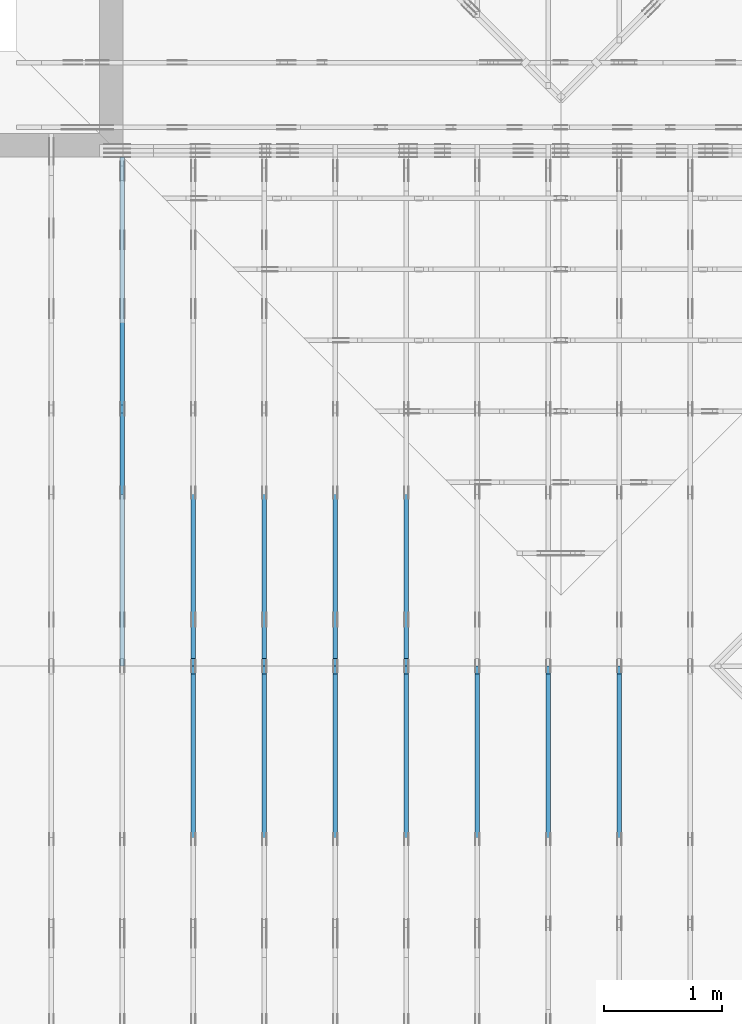
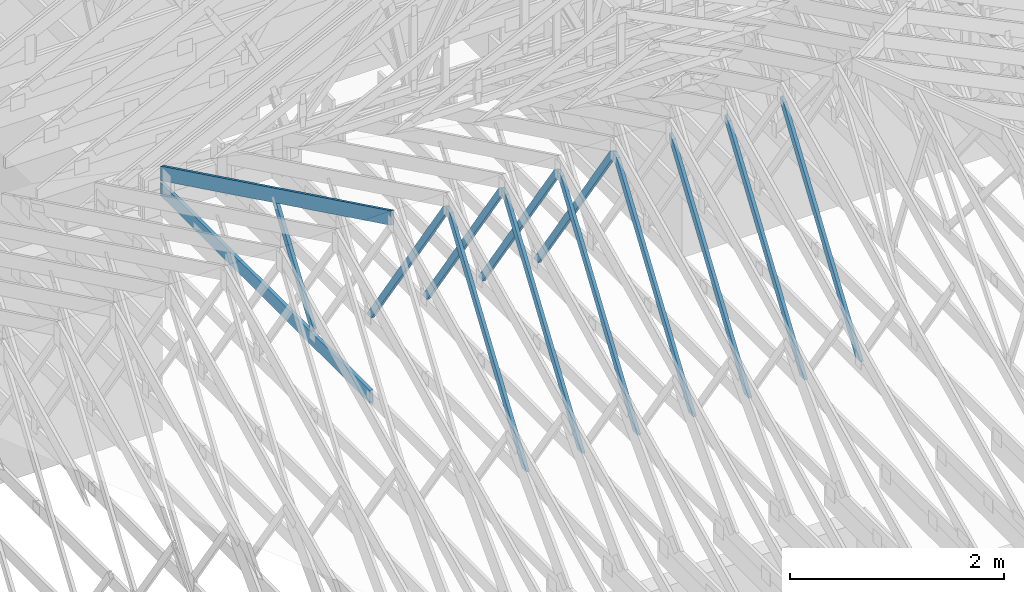
# One storey, part 17 of 159: 14 members, 8 elements without a shape of their own.
"""IFC2X3 building model written with IfcOpenShell, lengths in millimetres."""

from ifc_helpers import new_model, si_unit, frame, origin, origin_with_axes, origin_2d, place, context, project, spatial, faceted_brep, element, aggregate, save


model = new_model("IFC2X3")

# Units and contexts
model_context = context("Model", 3, precision=1e-05, world=origin())
plan_context = context("Plan", 2, precision=1e-05, world=origin_2d())
ifc_project = project(units=[si_unit("LENGTHUNIT", "METRE", prefix="MILLI"), si_unit("AREAUNIT", "SQUARE_METRE"), si_unit("VOLUMEUNIT", "CUBIC_METRE"), si_unit("SOLIDANGLEUNIT", "STERADIAN"), si_unit("PLANEANGLEUNIT", "RADIAN"), si_unit("MASSUNIT", "GRAM"), si_unit("TIMEUNIT", "SECOND"), si_unit("THERMODYNAMICTEMPERATUREUNIT", "DEGREE_CELSIUS"), si_unit("LUMINOUSINTENSITYUNIT", "LUMEN")], contexts=[model_context, plan_context])

# Site, building, storey
site_placement = place(None, origin_with_axes())
site = spatial("IfcSite", under=ifc_project, at=site_placement, CompositionType="ELEMENT")
building_placement = place(site_placement, origin_with_axes())
building = spatial("IfcBuilding", under=site, at=building_placement, Name="Plan 1", CompositionType="ELEMENT")
storey_placement = place(building_placement, origin_with_axes())
storey = spatial("IfcBuildingStorey", under=building, at=storey_placement, Name="Etasje 1", CompositionType="ELEMENT", Elevation=0.0)

# Assembly, member
assembly_1_placement = place(storey_placement, frame((15075.02226140475, -699.9989301294845, 1.1021457184401395e-15), z_axis=(-1.0, 1.836909530733566e-16, 6.123031769111886e-17), x_axis=(-1.836909530733566e-16, -1.0, 0.0)))
assembly_1 = element("IfcElementAssembly", 1, at=assembly_1_placement, inside=storey, Name="T7 (103)", AssemblyPlace="FACTORY", PredefinedType="TRUSS")
member_1_placement = place(assembly_1_placement, frame((-5230.134200945327, 2470.9490997577877, -36.0), z_axis=(0.0, 0.0, 1.0), x_axis=(0.5642475050069341, -0.8256056886271133, 0.0)))
member_1 = element("IfcMember", 2, at=member_1_placement, Name="T7-D10", context=model_context, shape_type="Brep", body=[
    faceted_brep([(2593.4163311647476, 73.00019205185345, 36.0), (64.12142578857947, 73.00019205185345, 36.0), (0.0, 36.500098826461, 36.0), (53.40677111084369, 6.283484799496364e-05, 36.0), (2543.5254730981324, 6.283484799496364e-05, 36.0), (64.12142578857947, 73.00019205185345, 7.852350543684446e-15), (2593.4163311647476, 73.00019205185345, 3.1759141172510683e-13), (2543.5254730981324, 6.283484799496364e-05, 3.114817455465041e-13), (53.40677111084369, 6.283484799496364e-05, 6.540227123947657e-15), (0.0, 36.500098826461, 0.0), (8.990210517012542e-05, 36.5000938930789, 3.944304526105059e-31), (8.990210517190178e-05, 36.50009389307889, 36.0), (64.12149423251047, 73.00009389364551, 36.0), (64.12149423251047, 73.00009389364551, 7.888609052210118e-31), (53.40680834923477, 9.3893645480847e-05, 1.1832913578315177e-30), (53.40680834923477, 9.389364548439971e-05, 36.0), (8.990210517723085e-05, 36.50009389307888, 36.0), (8.990210517723085e-05, 36.500093893078876, 3.944304526105059e-31), (2543.5255372683005, 9.389364500212836e-05, 1.1393273801051142e-28), (2543.5255372683005, 9.389364500433265e-05, 36.0), (53.40680834923478, 9.389364546174493e-05, 36.0), (53.40680834923478, 9.389364545954064e-05, 2.3922645400816085e-30), (2593.4162640800278, 73.00009389364232, -5.048709793414476e-29), (2593.4162640800278, 73.00009389364232, 36.0), (2543.5255372683, 9.38936470902263e-05, 36.0), (2543.5255372683, 9.38936470902263e-05, -5.048709793414476e-29), (64.12149423251049, 73.00009389364551, 0.0), (64.12149423251049, 73.00009389364551, 36.0), (2593.416264080028, 73.00009389364254, 36.0), (2593.416264080028, 73.00009389364254, 4.1809627976713626e-29)], [[[0, 1, 2, 3, 4]], [[5, 6, 7, 8, 9]], [[10, 11, 12, 13]], [[14, 15, 16, 17]], [[18, 19, 20, 21]], [[22, 23, 24, 25]], [[26, 27, 28, 29]]]),
])
aggregate(assembly_1, [member_1])

assembly_2_placement = place(storey_placement, frame((14475.022261404752, -699.9989301294836, 1.1021457184401395e-15), z_axis=(-1.0, 1.836909530733566e-16, 6.123031769111886e-17), x_axis=(-1.836909530733566e-16, -1.0, 0.0)))
assembly_2 = element("IfcElementAssembly", 3, at=assembly_2_placement, inside=storey, Name="T10 (102)", AssemblyPlace="FACTORY", PredefinedType="TRUSS")
member_2_placement = place(assembly_2_placement, frame((-5230.134200945327, 2470.9490997577877, -36.0), z_axis=(0.0, 0.0, 1.0), x_axis=(0.5642475050069341, -0.8256056886271133, 0.0)))
member_2 = element("IfcMember", 4, at=member_2_placement, Name="T10-D10", context=model_context, shape_type="Brep", body=[
    faceted_brep([(2593.4163311647476, 73.00019205185345, 36.0), (64.12142578857947, 73.00019205185345, 36.0), (0.0, 36.500098826461, 36.0), (53.40677111084369, 6.283484799496364e-05, 36.0), (2543.5254730981324, 6.283484799496364e-05, 36.0), (64.12142578857947, 73.00019205185345, 7.852350543684446e-15), (2593.4163311647476, 73.00019205185345, 3.1759141172510683e-13), (2543.5254730981324, 6.283484799496364e-05, 3.114817455465041e-13), (53.40677111084369, 6.283484799496364e-05, 6.540227123947657e-15), (0.0, 36.500098826461, 0.0), (8.990210517012542e-05, 36.5000938930789, 3.944304526105059e-31), (8.990210517190178e-05, 36.50009389307889, 36.0), (64.12149423251047, 73.00009389364551, 36.0), (64.12149423251047, 73.00009389364551, 7.888609052210118e-31), (53.40680834923477, 9.3893645480847e-05, 1.1832913578315177e-30), (53.40680834923477, 9.389364548439971e-05, 36.0), (8.990210517723085e-05, 36.50009389307888, 36.0), (8.990210517723085e-05, 36.500093893078876, 3.944304526105059e-31), (2543.5255372683005, 9.389364500212836e-05, 1.1393273801051142e-28), (2543.5255372683005, 9.389364500433265e-05, 36.0), (53.40680834923478, 9.389364546174493e-05, 36.0), (53.40680834923478, 9.389364545954064e-05, 2.3922645400816085e-30), (2593.4162640800278, 73.00009389364232, -5.048709793414476e-29), (2593.4162640800278, 73.00009389364232, 36.0), (2543.5255372683, 9.38936470902263e-05, 36.0), (2543.5255372683, 9.38936470902263e-05, -5.048709793414476e-29), (64.12149423251049, 73.00009389364551, 0.0), (64.12149423251049, 73.00009389364551, 36.0), (2593.416264080028, 73.00009389364254, 36.0), (2593.416264080028, 73.00009389364254, 4.1809627976713626e-29)], [[[0, 1, 2, 3, 4]], [[5, 6, 7, 8, 9]], [[10, 11, 12, 13]], [[14, 15, 16, 17]], [[18, 19, 20, 21]], [[22, 23, 24, 25]], [[26, 27, 28, 29]]]),
])
aggregate(assembly_2, [member_2])

assembly_3_placement = place(storey_placement, frame((13875.022261404752, -699.9989301294836, 1.1021457184401395e-15), z_axis=(-1.0, 1.836909530733566e-16, 6.123031769111886e-17), x_axis=(-1.836909530733566e-16, -1.0, 0.0)))
assembly_3 = element("IfcElementAssembly", 5, at=assembly_3_placement, inside=storey, Name="T6 (101)", AssemblyPlace="FACTORY", PredefinedType="TRUSS")
member_3_placement = place(assembly_3_placement, frame((-5230.134200945327, 2470.9490997577877, -36.0), z_axis=(0.0, 0.0, 1.0), x_axis=(0.5642475050069341, -0.8256056886271133, 0.0)))
member_3 = element("IfcMember", 6, at=member_3_placement, Name="T6-D10", context=model_context, shape_type="Brep", body=[
    faceted_brep([(2593.4163311647476, 73.00019205185345, 36.0), (64.12142578857947, 73.00019205185345, 36.0), (0.0, 36.500098826461, 36.0), (53.40677111084369, 6.283484799496364e-05, 36.0), (2543.5254730981324, 6.283484799496364e-05, 36.0), (64.12142578857947, 73.00019205185345, 7.852350543684446e-15), (2593.4163311647476, 73.00019205185345, 3.1759141172510683e-13), (2543.5254730981324, 6.283484799496364e-05, 3.114817455465041e-13), (53.40677111084369, 6.283484799496364e-05, 6.540227123947657e-15), (0.0, 36.500098826461, 0.0), (8.990210517012542e-05, 36.5000938930789, 3.944304526105059e-31), (8.990210517190178e-05, 36.50009389307889, 36.0), (64.12149423251047, 73.00009389364551, 36.0), (64.12149423251047, 73.00009389364551, 7.888609052210118e-31), (53.40680834923477, 9.3893645480847e-05, 1.1832913578315177e-30), (53.40680834923477, 9.389364548439971e-05, 36.0), (8.990210517723085e-05, 36.50009389307888, 36.0), (8.990210517723085e-05, 36.500093893078876, 3.944304526105059e-31), (2543.5255372683005, 9.389364500212836e-05, 1.1393273801051142e-28), (2543.5255372683005, 9.389364500433265e-05, 36.0), (53.40680834923478, 9.389364546174493e-05, 36.0), (53.40680834923478, 9.389364545954064e-05, 2.3922645400816085e-30), (2593.4162640800278, 73.00009389364232, -5.048709793414476e-29), (2593.4162640800278, 73.00009389364232, 36.0), (2543.5255372683, 9.38936470902263e-05, 36.0), (2543.5255372683, 9.38936470902263e-05, -5.048709793414476e-29), (64.12149423251049, 73.00009389364551, 0.0), (64.12149423251049, 73.00009389364551, 36.0), (2593.416264080028, 73.00009389364254, 36.0), (2593.416264080028, 73.00009389364254, 4.1809627976713626e-29)], [[[0, 1, 2, 3, 4]], [[5, 6, 7, 8, 9]], [[10, 11, 12, 13]], [[14, 15, 16, 17]], [[18, 19, 20, 21]], [[22, 23, 24, 25]], [[26, 27, 28, 29]]]),
])
aggregate(assembly_3, [member_3])

# Assembly, members
assembly_4_placement = place(storey_placement, frame((13275.022261404752, -699.9989301294836, 1.1021457184401395e-15), z_axis=(-1.0, 1.836909530733566e-16, 6.123031769111886e-17), x_axis=(-1.836909530733566e-16, -1.0, 0.0)))
assembly_4 = element("IfcElementAssembly", 7, at=assembly_4_placement, inside=storey, Name="T6 (100)", AssemblyPlace="FACTORY", PredefinedType="TRUSS")
member_4_placement = place(assembly_4_placement, frame((-5230.134196319675, 2512.1392759871583, -36.0), z_axis=(0.0, 0.0, 1.0), x_axis=(-0.5642475050074617, -0.8256056886267528, 0.0)))
member_4 = element("IfcMember", 8, at=member_4_placement, Name="T6-D10", context=model_context, shape_type="Brep", body=[
    faceted_brep([(2543.5256108538483, 72.99999048793325, 36.0), (53.406771110820955, 72.99999048793325, 36.0), (0.0, 36.50009322373626, 36.0), (64.12142578860312, 0.00011835360965051223, 36.0), (2593.4163311647717, 0.00011835360965051223, 36.0), (53.406771110820955, 72.99999048793325, 6.5402271239448724e-15), (2543.5256108538483, 72.99999048793325, 3.114817624161566e-13), (2593.4163311647717, 0.00011835360965051223, 3.175914117251098e-13), (64.12142578860312, 0.00011835360965051223, 7.852350543687342e-15), (0.0, 36.50009322373626, 0.0), (3.72532881449672e-05, 36.50017519275116, 3.944304526105059e-31), (3.72532881449672e-05, 36.50017519275116, 36.0), (53.40675570041866, 73.00017519218363, 36.0), (53.40675570041866, 73.00017519218363, 7.888609052210118e-31), (64.12144158709383, 0.00017519218362238576, 7.888609052210118e-31), (64.12144158709383, 0.00017519218362593847, 36.0), (3.7253288159178055e-05, 36.500175192751165, 36.0), (3.72532881574017e-05, 36.500175192751165, -3.944304526105059e-31), (2593.4162114323694, 0.0001751921831566568, 2.916933296842317e-29), (2593.4162114323694, 0.00017519218315886108, 36.0), (64.12144158709384, 0.00017519218362346966, 36.0), (64.12144158709384, 0.00017519218362126537, 7.212035881277958e-31), (2543.52548462057, 73.00017519218363, -8.473528143218631e-30), (2543.52548462057, 73.00017519218363, 36.0), (2593.41621143237, 0.00017519218386041757, 36.0), (2593.41621143237, 0.00017519218386041757, -9.018458054926462e-30), (53.40675570041867, 73.00017519218363, 0.0), (53.40675570041867, 73.00017519218363, 36.0), (2543.52548462057, 73.00017519218348, 36.0), (2543.52548462057, 73.00017519218348, -9.466330862652142e-30)], [[[0, 1, 2, 3, 4]], [[5, 6, 7, 8, 9]], [[10, 11, 12, 13]], [[14, 15, 16, 17]], [[18, 19, 20, 21]], [[22, 23, 24, 25]], [[26, 27, 28, 29]]]),
])
member_5_placement = place(assembly_4_placement, frame((-5230.134200945327, 2470.9490997577877, -36.0), z_axis=(0.0, 0.0, 1.0), x_axis=(0.5642475050069341, -0.8256056886271133, 0.0)))
member_5 = element("IfcMember", 9, at=member_5_placement, Name="T6-D10", context=model_context, shape_type="Brep", body=[
    faceted_brep([(2593.4163311647476, 73.00019205185345, 36.0), (64.12142578857947, 73.00019205185345, 36.0), (0.0, 36.500098826461, 36.0), (53.40677111084369, 6.283484799496364e-05, 36.0), (2543.5254730981324, 6.283484799496364e-05, 36.0), (64.12142578857947, 73.00019205185345, 7.852350543684446e-15), (2593.4163311647476, 73.00019205185345, 3.1759141172510683e-13), (2543.5254730981324, 6.283484799496364e-05, 3.114817455465041e-13), (53.40677111084369, 6.283484799496364e-05, 6.540227123947657e-15), (0.0, 36.500098826461, 0.0), (8.990210517012542e-05, 36.5000938930789, 3.944304526105059e-31), (8.990210517190178e-05, 36.50009389307889, 36.0), (64.12149423251047, 73.00009389364551, 36.0), (64.12149423251047, 73.00009389364551, 7.888609052210118e-31), (53.40680834923477, 9.3893645480847e-05, 1.1832913578315177e-30), (53.40680834923477, 9.389364548439971e-05, 36.0), (8.990210517723085e-05, 36.50009389307888, 36.0), (8.990210517723085e-05, 36.500093893078876, 3.944304526105059e-31), (2543.5255372683005, 9.389364500212836e-05, 1.1393273801051142e-28), (2543.5255372683005, 9.389364500433265e-05, 36.0), (53.40680834923478, 9.389364546174493e-05, 36.0), (53.40680834923478, 9.389364545954064e-05, 2.3922645400816085e-30), (2593.4162640800278, 73.00009389364232, -5.048709793414476e-29), (2593.4162640800278, 73.00009389364232, 36.0), (2543.5255372683, 9.38936470902263e-05, 36.0), (2543.5255372683, 9.38936470902263e-05, -5.048709793414476e-29), (64.12149423251049, 73.00009389364551, 0.0), (64.12149423251049, 73.00009389364551, 36.0), (2593.416264080028, 73.00009389364254, 36.0), (2593.416264080028, 73.00009389364254, 4.1809627976713626e-29)], [[[0, 1, 2, 3, 4]], [[5, 6, 7, 8, 9]], [[10, 11, 12, 13]], [[14, 15, 16, 17]], [[18, 19, 20, 21]], [[22, 23, 24, 25]], [[26, 27, 28, 29]]]),
])
aggregate(assembly_4, [member_4, member_5])

assembly_5_placement = place(storey_placement, frame((12675.022261404752, -699.9989301294854, 4.558494966049043e-13), z_axis=(-1.0, 1.836909530733566e-16, 6.123031769111886e-17), x_axis=(-1.836909530733566e-16, -1.0, 0.0)))
assembly_5 = element("IfcElementAssembly", 10, at=assembly_5_placement, inside=storey, Name="T6 (99)", AssemblyPlace="FACTORY", PredefinedType="TRUSS")
member_6_placement = place(assembly_5_placement, frame((-5230.134196319675, 2512.1392759871583, -36.0), z_axis=(0.0, 0.0, 1.0), x_axis=(-0.5642475050074617, -0.8256056886267528, 0.0)))
member_6 = element("IfcMember", 11, at=member_6_placement, Name="T6-D10", context=model_context, shape_type="Brep", body=[
    faceted_brep([(2543.5256108538483, 72.99999048793325, 36.0), (53.406771110820955, 72.99999048793325, 36.0), (0.0, 36.50009322373626, 36.0), (64.12142578860312, 0.00011835360965051223, 36.0), (2593.4163311647717, 0.00011835360965051223, 36.0), (53.406771110820955, 72.99999048793325, 6.5402271239448724e-15), (2543.5256108538483, 72.99999048793325, 3.114817624161566e-13), (2593.4163311647717, 0.00011835360965051223, 3.175914117251098e-13), (64.12142578860312, 0.00011835360965051223, 7.852350543687342e-15), (0.0, 36.50009322373626, 0.0), (3.72532881449672e-05, 36.50017519275116, 3.944304526105059e-31), (3.72532881449672e-05, 36.50017519275116, 36.0), (53.40675570041866, 73.00017519218363, 36.0), (53.40675570041866, 73.00017519218363, 7.888609052210118e-31), (64.12144158709383, 0.00017519218362238576, 7.888609052210118e-31), (64.12144158709383, 0.00017519218362593847, 36.0), (3.7253288159178055e-05, 36.500175192751165, 36.0), (3.72532881574017e-05, 36.500175192751165, -3.944304526105059e-31), (2593.4162114323694, 0.0001751921831566568, 2.916933296842317e-29), (2593.4162114323694, 0.00017519218315886108, 36.0), (64.12144158709384, 0.00017519218362346966, 36.0), (64.12144158709384, 0.00017519218362126537, 7.212035881277958e-31), (2543.52548462057, 73.00017519218363, -8.473528143218631e-30), (2543.52548462057, 73.00017519218363, 36.0), (2593.41621143237, 0.00017519218386041757, 36.0), (2593.41621143237, 0.00017519218386041757, -9.018458054926462e-30), (53.40675570041867, 73.00017519218363, 0.0), (53.40675570041867, 73.00017519218363, 36.0), (2543.52548462057, 73.00017519218348, 36.0), (2543.52548462057, 73.00017519218348, -9.466330862652142e-30)], [[[0, 1, 2, 3, 4]], [[5, 6, 7, 8, 9]], [[10, 11, 12, 13]], [[14, 15, 16, 17]], [[18, 19, 20, 21]], [[22, 23, 24, 25]], [[26, 27, 28, 29]]]),
])
member_7_placement = place(assembly_5_placement, frame((-5230.134200945327, 2470.9490997577877, -36.0), z_axis=(0.0, 0.0, 1.0), x_axis=(0.5642475050069341, -0.8256056886271133, 0.0)))
member_7 = element("IfcMember", 12, at=member_7_placement, Name="T6-D10", context=model_context, shape_type="Brep", body=[
    faceted_brep([(2593.4163311647476, 73.00019205185345, 36.0), (64.12142578857947, 73.00019205185345, 36.0), (0.0, 36.500098826461, 36.0), (53.40677111084369, 6.283484799496364e-05, 36.0), (2543.5254730981324, 6.283484799496364e-05, 36.0), (64.12142578857947, 73.00019205185345, 7.852350543684446e-15), (2593.4163311647476, 73.00019205185345, 3.1759141172510683e-13), (2543.5254730981324, 6.283484799496364e-05, 3.114817455465041e-13), (53.40677111084369, 6.283484799496364e-05, 6.540227123947657e-15), (0.0, 36.500098826461, 0.0), (8.990210517012542e-05, 36.5000938930789, 3.944304526105059e-31), (8.990210517190178e-05, 36.50009389307889, 36.0), (64.12149423251047, 73.00009389364551, 36.0), (64.12149423251047, 73.00009389364551, 7.888609052210118e-31), (53.40680834923477, 9.3893645480847e-05, 1.1832913578315177e-30), (53.40680834923477, 9.389364548439971e-05, 36.0), (8.990210517723085e-05, 36.50009389307888, 36.0), (8.990210517723085e-05, 36.500093893078876, 3.944304526105059e-31), (2543.5255372683005, 9.389364500212836e-05, 1.1393273801051142e-28), (2543.5255372683005, 9.389364500433265e-05, 36.0), (53.40680834923478, 9.389364546174493e-05, 36.0), (53.40680834923478, 9.389364545954064e-05, 2.3922645400816085e-30), (2593.4162640800278, 73.00009389364232, -5.048709793414476e-29), (2593.4162640800278, 73.00009389364232, 36.0), (2543.5255372683, 9.38936470902263e-05, 36.0), (2543.5255372683, 9.38936470902263e-05, -5.048709793414476e-29), (64.12149423251049, 73.00009389364551, 0.0), (64.12149423251049, 73.00009389364551, 36.0), (2593.416264080028, 73.00009389364254, 36.0), (2593.416264080028, 73.00009389364254, 4.1809627976713626e-29)], [[[0, 1, 2, 3, 4]], [[5, 6, 7, 8, 9]], [[10, 11, 12, 13]], [[14, 15, 16, 17]], [[18, 19, 20, 21]], [[22, 23, 24, 25]], [[26, 27, 28, 29]]]),
])
aggregate(assembly_5, [member_6, member_7])

assembly_6_placement = place(storey_placement, frame((12075.022261404752, -699.9989301294854, 4.558494966049043e-13), z_axis=(-1.0, 1.836909530733566e-16, 6.123031769111886e-17), x_axis=(-1.836909530733566e-16, -1.0, 0.0)))
assembly_6 = element("IfcElementAssembly", 13, at=assembly_6_placement, inside=storey, Name="T5 (98)", AssemblyPlace="FACTORY", PredefinedType="TRUSS")
member_8_placement = place(assembly_6_placement, frame((-5230.134196319675, 2512.1392759871583, -36.0), z_axis=(0.0, 0.0, 1.0), x_axis=(-0.5642475050074617, -0.8256056886267528, 0.0)))
member_8 = element("IfcMember", 14, at=member_8_placement, Name="T5-D10", context=model_context, shape_type="Brep", body=[
    faceted_brep([(2543.5256108538483, 72.99999048793325, 36.0), (53.406771110820955, 72.99999048793325, 36.0), (0.0, 36.50009322373626, 36.0), (64.12142578860312, 0.00011835360965051223, 36.0), (2593.4163311647717, 0.00011835360965051223, 36.0), (53.406771110820955, 72.99999048793325, 6.5402271239448724e-15), (2543.5256108538483, 72.99999048793325, 3.114817624161566e-13), (2593.4163311647717, 0.00011835360965051223, 3.175914117251098e-13), (64.12142578860312, 0.00011835360965051223, 7.852350543687342e-15), (0.0, 36.50009322373626, 0.0), (3.72532881449672e-05, 36.50017519275116, 3.944304526105059e-31), (3.72532881449672e-05, 36.50017519275116, 36.0), (53.40675570041866, 73.00017519218363, 36.0), (53.40675570041866, 73.00017519218363, 7.888609052210118e-31), (64.12144158709383, 0.00017519218362238576, 7.888609052210118e-31), (64.12144158709383, 0.00017519218362593847, 36.0), (3.7253288159178055e-05, 36.500175192751165, 36.0), (3.72532881574017e-05, 36.500175192751165, -3.944304526105059e-31), (2593.4162114323694, 0.0001751921831566568, 2.916933296842317e-29), (2593.4162114323694, 0.00017519218315886108, 36.0), (64.12144158709384, 0.00017519218362346966, 36.0), (64.12144158709384, 0.00017519218362126537, 7.212035881277958e-31), (2543.52548462057, 73.00017519218363, -8.473528143218631e-30), (2543.52548462057, 73.00017519218363, 36.0), (2593.41621143237, 0.00017519218386041757, 36.0), (2593.41621143237, 0.00017519218386041757, -9.018458054926462e-30), (53.40675570041867, 73.00017519218363, 0.0), (53.40675570041867, 73.00017519218363, 36.0), (2543.52548462057, 73.00017519218348, 36.0), (2543.52548462057, 73.00017519218348, -9.466330862652142e-30)], [[[0, 1, 2, 3, 4]], [[5, 6, 7, 8, 9]], [[10, 11, 12, 13]], [[14, 15, 16, 17]], [[18, 19, 20, 21]], [[22, 23, 24, 25]], [[26, 27, 28, 29]]]),
])
member_9_placement = place(assembly_6_placement, frame((-5230.134200945327, 2470.9490997577877, -36.0), z_axis=(0.0, 0.0, 1.0), x_axis=(0.5642475050069341, -0.8256056886271133, 0.0)))
member_9 = element("IfcMember", 15, at=member_9_placement, Name="T5-D10", context=model_context, shape_type="Brep", body=[
    faceted_brep([(2593.4163311647476, 73.00019205185345, 36.0), (64.12142578857947, 73.00019205185345, 36.0), (0.0, 36.500098826461, 36.0), (53.40677111084369, 6.283484799496364e-05, 36.0), (2543.5254730981324, 6.283484799496364e-05, 36.0), (64.12142578857947, 73.00019205185345, 7.852350543684446e-15), (2593.4163311647476, 73.00019205185345, 3.1759141172510683e-13), (2543.5254730981324, 6.283484799496364e-05, 3.114817455465041e-13), (53.40677111084369, 6.283484799496364e-05, 6.540227123947657e-15), (0.0, 36.500098826461, 0.0), (8.990210517012542e-05, 36.5000938930789, 3.944304526105059e-31), (8.990210517190178e-05, 36.50009389307889, 36.0), (64.12149423251047, 73.00009389364551, 36.0), (64.12149423251047, 73.00009389364551, 7.888609052210118e-31), (53.40680834923477, 9.3893645480847e-05, 1.1832913578315177e-30), (53.40680834923477, 9.389364548439971e-05, 36.0), (8.990210517723085e-05, 36.50009389307888, 36.0), (8.990210517723085e-05, 36.500093893078876, 3.944304526105059e-31), (2543.5255372683005, 9.389364500212836e-05, 1.1393273801051142e-28), (2543.5255372683005, 9.389364500433265e-05, 36.0), (53.40680834923478, 9.389364546174493e-05, 36.0), (53.40680834923478, 9.389364545954064e-05, 2.3922645400816085e-30), (2593.4162640800278, 73.00009389364232, -5.048709793414476e-29), (2593.4162640800278, 73.00009389364232, 36.0), (2543.5255372683, 9.38936470902263e-05, 36.0), (2543.5255372683, 9.38936470902263e-05, -5.048709793414476e-29), (64.12149423251049, 73.00009389364551, 0.0), (64.12149423251049, 73.00009389364551, 36.0), (2593.416264080028, 73.00009389364254, 36.0), (2593.416264080028, 73.00009389364254, 4.1809627976713626e-29)], [[[0, 1, 2, 3, 4]], [[5, 6, 7, 8, 9]], [[10, 11, 12, 13]], [[14, 15, 16, 17]], [[18, 19, 20, 21]], [[22, 23, 24, 25]], [[26, 27, 28, 29]]]),
])
aggregate(assembly_6, [member_8, member_9])

assembly_7_placement = place(storey_placement, frame((11475.022261404752, -699.9989301294845, 1.1021457184401395e-15), z_axis=(-1.0, 1.836909530733566e-16, 6.123031769111886e-17), x_axis=(-1.836909530733566e-16, -1.0, 0.0)))
assembly_7 = element("IfcElementAssembly", 16, at=assembly_7_placement, inside=storey, Name="T5 (97)", AssemblyPlace="FACTORY", PredefinedType="TRUSS")
member_10_placement = place(assembly_7_placement, frame((-5230.134196319675, 2512.1392759871583, -36.0), z_axis=(0.0, 0.0, 1.0), x_axis=(-0.5642475050074617, -0.8256056886267528, 0.0)))
member_10 = element("IfcMember", 17, at=member_10_placement, Name="T5-D10", context=model_context, shape_type="Brep", body=[
    faceted_brep([(2543.5256108538483, 72.99999048793325, 36.0), (53.406771110820955, 72.99999048793325, 36.0), (0.0, 36.50009322373626, 36.0), (64.12142578860312, 0.00011835360965051223, 36.0), (2593.4163311647717, 0.00011835360965051223, 36.0), (53.406771110820955, 72.99999048793325, 6.5402271239448724e-15), (2543.5256108538483, 72.99999048793325, 3.114817624161566e-13), (2593.4163311647717, 0.00011835360965051223, 3.175914117251098e-13), (64.12142578860312, 0.00011835360965051223, 7.852350543687342e-15), (0.0, 36.50009322373626, 0.0), (3.72532881449672e-05, 36.50017519275116, 3.944304526105059e-31), (3.72532881449672e-05, 36.50017519275116, 36.0), (53.40675570041866, 73.00017519218363, 36.0), (53.40675570041866, 73.00017519218363, 7.888609052210118e-31), (64.12144158709383, 0.00017519218362238576, 7.888609052210118e-31), (64.12144158709383, 0.00017519218362593847, 36.0), (3.7253288159178055e-05, 36.500175192751165, 36.0), (3.72532881574017e-05, 36.500175192751165, -3.944304526105059e-31), (2593.4162114323694, 0.0001751921831566568, 2.916933296842317e-29), (2593.4162114323694, 0.00017519218315886108, 36.0), (64.12144158709384, 0.00017519218362346966, 36.0), (64.12144158709384, 0.00017519218362126537, 7.212035881277958e-31), (2543.52548462057, 73.00017519218363, -8.473528143218631e-30), (2543.52548462057, 73.00017519218363, 36.0), (2593.41621143237, 0.00017519218386041757, 36.0), (2593.41621143237, 0.00017519218386041757, -9.018458054926462e-30), (53.40675570041867, 73.00017519218363, 0.0), (53.40675570041867, 73.00017519218363, 36.0), (2543.52548462057, 73.00017519218348, 36.0), (2543.52548462057, 73.00017519218348, -9.466330862652142e-30)], [[[0, 1, 2, 3, 4]], [[5, 6, 7, 8, 9]], [[10, 11, 12, 13]], [[14, 15, 16, 17]], [[18, 19, 20, 21]], [[22, 23, 24, 25]], [[26, 27, 28, 29]]]),
])
member_11_placement = place(assembly_7_placement, frame((-5230.134200945327, 2470.9490997577877, -36.0), z_axis=(0.0, 0.0, 1.0), x_axis=(0.5642475050069341, -0.8256056886271133, 0.0)))
member_11 = element("IfcMember", 18, at=member_11_placement, Name="T5-D10", context=model_context, shape_type="Brep", body=[
    faceted_brep([(2593.4163311647476, 73.00019205185345, 36.0), (64.12142578857947, 73.00019205185345, 36.0), (0.0, 36.500098826461, 36.0), (53.40677111084369, 6.283484799496364e-05, 36.0), (2543.5254730981324, 6.283484799496364e-05, 36.0), (64.12142578857947, 73.00019205185345, 7.852350543684446e-15), (2593.4163311647476, 73.00019205185345, 3.1759141172510683e-13), (2543.5254730981324, 6.283484799496364e-05, 3.114817455465041e-13), (53.40677111084369, 6.283484799496364e-05, 6.540227123947657e-15), (0.0, 36.500098826461, 0.0), (8.990210517012542e-05, 36.5000938930789, 3.944304526105059e-31), (8.990210517190178e-05, 36.50009389307889, 36.0), (64.12149423251047, 73.00009389364551, 36.0), (64.12149423251047, 73.00009389364551, 7.888609052210118e-31), (53.40680834923477, 9.3893645480847e-05, 1.1832913578315177e-30), (53.40680834923477, 9.389364548439971e-05, 36.0), (8.990210517723085e-05, 36.50009389307888, 36.0), (8.990210517723085e-05, 36.500093893078876, 3.944304526105059e-31), (2543.5255372683005, 9.389364500212836e-05, 1.1393273801051142e-28), (2543.5255372683005, 9.389364500433265e-05, 36.0), (53.40680834923478, 9.389364546174493e-05, 36.0), (53.40680834923478, 9.389364545954064e-05, 2.3922645400816085e-30), (2593.4162640800278, 73.00009389364232, -5.048709793414476e-29), (2593.4162640800278, 73.00009389364232, 36.0), (2543.5255372683, 9.38936470902263e-05, 36.0), (2543.5255372683, 9.38936470902263e-05, -5.048709793414476e-29), (64.12149423251049, 73.00009389364551, 0.0), (64.12149423251049, 73.00009389364551, 36.0), (2593.416264080028, 73.00009389364254, 36.0), (2593.416264080028, 73.00009389364254, 4.1809627976713626e-29)], [[[0, 1, 2, 3, 4]], [[5, 6, 7, 8, 9]], [[10, 11, 12, 13]], [[14, 15, 16, 17]], [[18, 19, 20, 21]], [[22, 23, 24, 25]], [[26, 27, 28, 29]]]),
])
aggregate(assembly_7, [member_10, member_11])

assembly_8_placement = place(storey_placement, frame((10875.02226140475, -699.9989301294845, 1.1021457184401395e-15), z_axis=(-1.0, 1.836909530733566e-16, 6.123031769111886e-17), x_axis=(-1.836909530733566e-16, -1.0, 0.0)))
assembly_8 = element("IfcElementAssembly", 19, at=assembly_8_placement, inside=storey, Name="T4 (96)", AssemblyPlace="FACTORY", PredefinedType="TRUSS")
member_12_placement = place(assembly_8_placement, frame((-9501.999001850085, 393.31874236033445, -36.0), z_axis=(0.0, 0.0, 1.0), x_axis=(0.898794046299167, 0.4383711467890774, 0.0)))
member_12 = element("IfcMember", 20, at=member_12_placement, Name="T4-O7", context=model_context, shape_type="Brep", body=[
    faceted_brep([(4858.597426386083, 148.0000464085042, 36.0), (72.18442876594781, 148.0000464085042, 36.0), (0.0, 4.924460790789453e-05, 36.0), (4786.4130243761865, 4.924460790789453e-05, 36.0), (72.18442876594781, 148.0000464085042, 8.839751011381847e-15), (4858.597426386083, 148.0000464085042, 5.949869279017447e-13), (4786.4130243761865, 4.924460790789453e-05, 5.861471801669259e-13), (0.0, 4.924460790789453e-05, 0.0), (7.980784358056719e-05, 1.3278602410132117e-09, -2.8264752261567097e-31), (7.98078435825484e-05, 1.3278592747180255e-09, 36.0), (72.18450291523912, 148.00000000060666, 36.0), (72.18450291523912, 148.00000000060666, 7.5072674000576e-31), (4786.4130325507385, -3.639016950303552e-12, 2.228181639504565e-28), (4786.4130325507385, -3.636812658866672e-12, 36.0), (7.980784357641824e-05, 1.3278644688192357e-09, 36.0), (7.980784357641824e-05, 1.3278622645277988e-09, 3.715227955945574e-36), (4858.597455658952, 148.0000000009518, 5.048709793414476e-29), (4858.597455658952, 148.0000000009518, 36.0), (4786.413032550739, 0.0, 36.0), (4786.413032550739, 0.0, 5.048709793414476e-29), (72.18450291523914, 148.00000000060663, 0.0), (72.18450291523914, 148.00000000060663, 36.0), (4858.597455658951, 148.00000000095176, 36.0), (4858.597455658951, 148.00000000095176, -2.997671439839845e-29)], [[[0, 1, 2, 3]], [[4, 5, 6, 7]], [[8, 9, 10, 11]], [[12, 13, 14, 15]], [[16, 17, 18, 19]], [[20, 21, 22, 23]]]),
])
member_13_placement = place(assembly_8_placement, frame((-5591.18115234375, 371.0, -36.0), z_axis=(0.0, 0.0, 1.0), x_axis=(-1.0, 1.2246063538223773e-16, 0.0)))
member_13 = element("IfcMember", 21, at=member_13_placement, Name="T4-U39", context=model_context, shape_type="Brep", body=[
    faceted_brep([(3910.81787109375, 148.00000000000048, 36.0), (0.0, 148.00000000000048, 36.0), (0.0, 0.0, 36.0), (3910.81787109375, 0.0, 36.0), (0.0, 148.00000000000048, 0.0), (3910.81787109375, 148.00000000000048, 4.789212413583509e-13), (3910.81787109375, 0.0, 4.789212413583509e-13), (0.0, 0.0, 0.0), (0.0001433398574590683, 3.979039320256561e-13, 0.0), (0.0001433398574612726, 3.979039320256561e-13, 36.0), (0.00014333985747939676, 148.00000000000037, 36.0), (0.00014333985747719247, 148.00000000000037, -1.1097494219785373e-30), (3910.817777776101, -3.204779149536956e-13, 4.746728930957506e-29), (3910.817777776101, -3.182736235168153e-13, 36.0), (0.0001433398574590683, 4.001081950488681e-13, 36.0), (0.0001433398574590683, 3.9790390361198783e-13, 1.73977793531565e-36), (3910.817777776101, 148.00000000000048, 0.0), (3910.817777776101, 148.00000000000048, 36.0), (3910.817777776101, 4.547473508864641e-13, 36.0), (3910.817777776101, 4.547473508864641e-13, 0.0), (0.0001433398574590683, 148.00000000000037, 0.0), (0.0001433398574590683, 148.00000000000037, 36.0), (3910.817777776101, 148.0000000000001, 36.0), (3910.817777776101, 148.00000000000014, -2.208810534618833e-29)], [[[0, 1, 2, 3]], [[4, 5, 6, 7]], [[8, 9, 10, 11]], [[12, 13, 14, 15]], [[16, 17, 18, 19]], [[20, 21, 22, 23]]]),
])
member_14_placement = place(assembly_8_placement, frame((-7407.03695472166, 1415.0999762480442, -36.0), z_axis=(0.0, 0.0, 1.0), x_axis=(0.5642475050064201, -0.8256056886274645, 0.0)))
member_14 = element("IfcMember", 22, at=member_14_placement, Name="T4-D42", context=model_context, shape_type="Brep", body=[
    faceted_brep([(1236.1859046255386, 72.99999679664234, 36.0), (10.714742691100582, 72.99999679664234, 36.0), (8.80134111866937e-05, 0.0003439493775658775, 36.0), (1264.647265190018, 0.0003439493775658775, 36.0), (10.714742691100582, 72.99999679664234, 1.312134197909365e-15), (1236.1859046255386, 72.99999679664234, 1.5138411133100978e-13), (1264.647265190018, 0.0003439493775658775, 1.548695076295789e-13), (8.80134111866937e-05, 0.0003439493775658775, 1.077817825608066e-20), (1.2441219929271163e-16, 0.00017519218454252033, -7.699393958337917e-33), (2.305335691224139e-15, 0.00017519218454220022, 36.0), (10.714685884795475, 73.00017519218454, 36.0), (10.714685884795474, 73.00017519218454, -2.956283656724794e-32), (1264.6473849224226, 0.00017519218655669935, 4.373824669985916e-29), (1264.6473849224226, 0.00017519218655890365, 36.0), (-3.510681399126273e-30, 0.0001751921845447429, 36.0), (0.0, 0.0001751921845425386, 0.0), (1236.1860298802894, 73.00017519218727, -1.3795914725131465e-29), (1236.1860298802894, 73.00017519218727, 36.0), (1264.6473849224226, 0.0001751921872710227, 36.0), (1264.6473849224226, 0.0001751921872710227, -1.4037355718167356e-29), (10.714685884795474, 73.00017519218454, 0.0), (10.714685884795474, 73.00017519218453, 36.0), (1236.1860298802894, 73.00017519218719, 36.0), (1236.1860298802894, 73.00017519218719, -5.5220263365470826e-30)], [[[0, 1, 2, 3]], [[4, 5, 6, 7]], [[8, 9, 10, 11]], [[12, 13, 14, 15]], [[16, 17, 18, 19]], [[20, 21, 22, 23]]]),
])
aggregate(assembly_8, [member_12, member_13, member_14])

save(model, "model.ifc")
